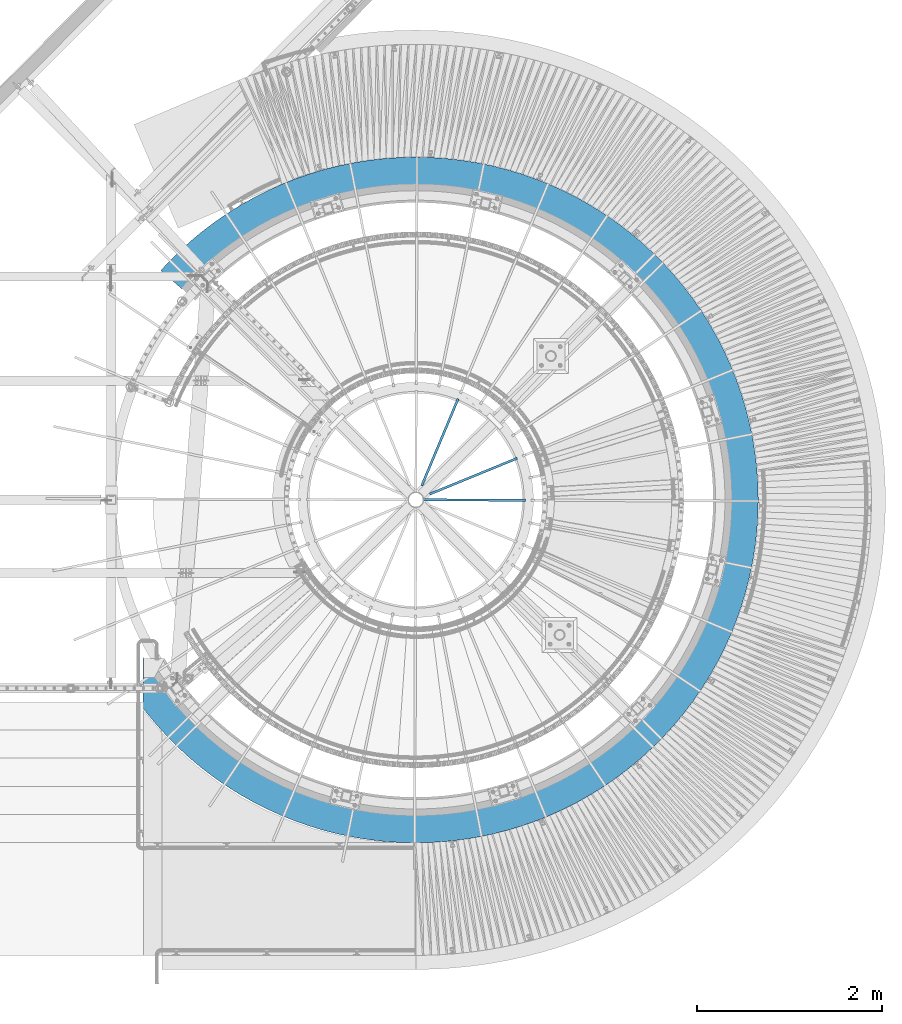
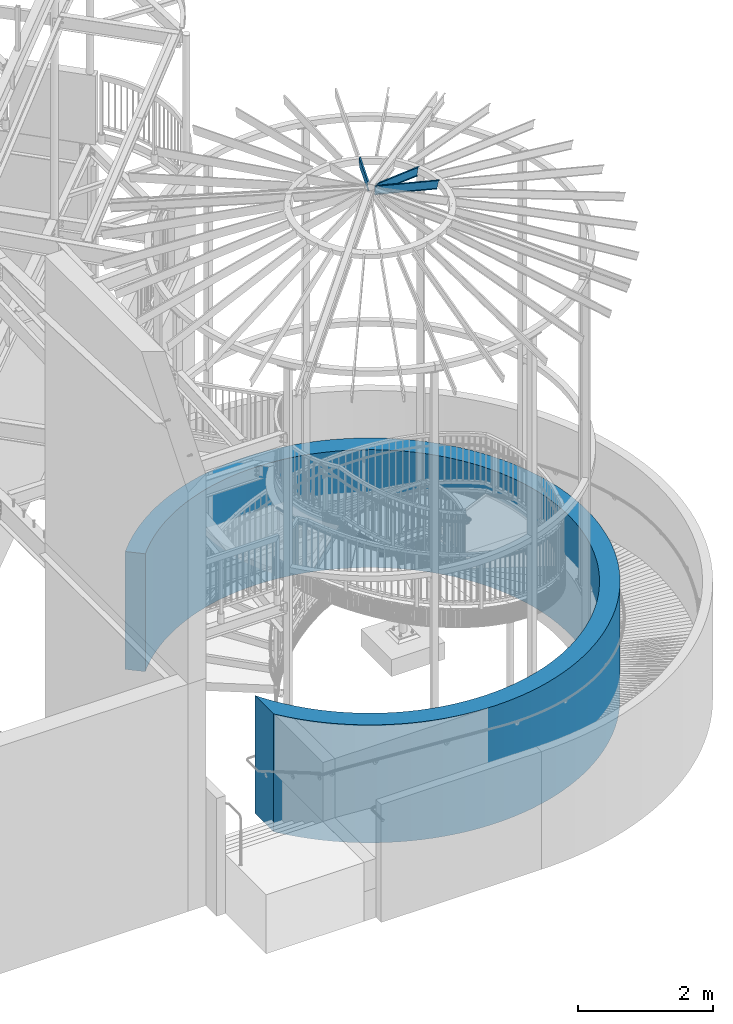
# One storey, part 350 of 975: 4 beams.
"""IFC2X3 building model written with IfcOpenShell, lengths in millimetres."""

from ifc_helpers import new_model, si_unit, frame, origin_with_axes, place, context, subcontext, project, spatial, faceted_brep, material, type_object, element, save


model = new_model("IFC2X3")

# Units and contexts
model_context = context("Model", 3, precision=1e-05, world=origin_with_axes())
body_context = subcontext(model_context, "Body", "Model", "MODEL_VIEW")
ifc_project = project(units=[si_unit("LENGTHUNIT", "METRE", prefix="MILLI"), si_unit("AREAUNIT", "SQUARE_METRE"), si_unit("VOLUMEUNIT", "CUBIC_METRE"), si_unit("MASSUNIT", "GRAM", prefix="KILO"), si_unit("TIMEUNIT", "SECOND"), si_unit("PLANEANGLEUNIT", "RADIAN"), si_unit("SOLIDANGLEUNIT", "STERADIAN"), si_unit("THERMODYNAMICTEMPERATUREUNIT", "DEGREE_CELSIUS"), si_unit("LUMINOUSINTENSITYUNIT", "LUMEN")], contexts=[model_context])

# Site, building, storey
site_placement = place(None, origin_with_axes())
site = spatial("IfcSite", under=ifc_project, at=site_placement, CompositionType="ELEMENT")
building_placement = place(site_placement, origin_with_axes())
building = spatial("IfcBuilding", under=site, at=building_placement, Name="Undefined", CompositionType="ELEMENT")
storey_placement = place(building_placement, origin_with_axes())
storey = spatial("IfcBuildingStorey", under=building, at=storey_placement, Name="Undefined", CompositionType="ELEMENT", Elevation=0.0)

# Beams
ifc_material = material(Name="STEEL/Zero_Density")
beam_type_1 = type_object("IfcBeamType", PredefinedType="NOTDEFINED")
beam_1_placement = place(storey_placement, frame((34730.3713409312, 3401.89164501969, 2133.6), z_axis=(0.0, -1.0, 0.0), x_axis=(0.0, 0.0, -1.0)))
element("IfcBeam", 1, at=beam_1_placement, inside=storey, type_object=beam_type_1, material=ifc_material, Name="WALL", context=body_context, shape_type="Brep", body=[
    faceted_brep([(2133.6, -2946.39999055969, 2250.34763282551), (0.0, -2946.39999055698, 2250.34763282907), (0.0, -2946.39996710213, 1702.37863439887), (2133.6, -2946.39996710377, 1702.37863439599), (2133.6, -2524.9126198538, -2281.19803068392), (0.0, -2524.91261985427, -2281.19803068341), (0.0, -2753.92744116245, -2482.30814659826), (2133.6, -2753.92744116215, -2482.3081465986), (0.0, -2921.81631390331, 1745.70398057874), (2133.6, -2921.81631390331, 1745.70398057874), (0.0, -2840.55352636582, 1875.03296607038), (2133.6, -2840.55352636582, 1875.03296607038), (0.0, -2753.57024205457, 2000.58588470266), (2133.6, -2753.57024205457, 2000.58588470266), (0.0, -2661.04163372819, 2122.10988960639), (2133.6, -2661.04163372819, 2122.10988960639), (0.0, -2563.15404168989, 2239.36024760841), (2133.6, -2563.15404168989, 2239.36024760841), (0.0, -2460.10459852291, 2352.10083209169), (2133.6, -2460.10459852291, 2352.10083209169), (0.0, -2352.10083209169, 2460.10459852291), (2133.6, -2352.10083209169, 2460.10459852291), (0.0, -2239.36024760841, 2563.15404168989), (2133.6, -2239.36024760841, 2563.15404168989), (0.0, -2122.10988960638, 2661.04163372819), (2133.6, -2122.10988960638, 2661.04163372819), (0.0, -2000.58588470266, 2753.57024205457), (2133.6, -2000.58588470266, 2753.57024205457), (0.0, -1875.03296607037, 2840.55352636583), (2133.6, -1875.03296607037, 2840.55352636583), (0.0, -1745.70398057874, 2921.81631390331), (2133.6, -1745.70398057874, 2921.81631390331), (0.0, -1612.8593795931, 2997.19495222759), (2133.6, -1612.8593795931, 2997.19495222759), (0.0, -1476.76669446052, 3066.53763879267), (2133.6, -1476.76669446052, 3066.53763879267), (0.0, -1337.69999773729, 3129.70472665612), (2133.6, -1337.69999773729, 3129.70472665612), (0.0, -1195.93935124326, 3186.56900570941), (2133.6, -1195.93935124326, 3186.56900570941), (0.0, -1051.77024205457, 3237.01595886219), (2133.6, -1051.77024205457, 3237.01595886219), (0.0, -905.483007570736, 3280.94399266441), (2133.6, -905.483007570736, 3280.94399266441), (0.0, -757.372250813714, 3318.26464190205), (2133.6, -757.372250813714, 3318.26464190205), (0.0, -607.736247136636, 3348.9027477543), (2133.6, -607.736247136636, 3348.9027477543), (0.0, -456.876343536969, 3372.79660915334), (2133.6, -456.876343536969, 3372.79660915334), (0.0, -305.096351783723, 3389.8981070422), (2133.6, -305.096351783723, 3389.8981070422), (0.0, -152.701936581012, 3400.17280128002), (2133.6, -152.701936581012, 3400.17280128002), (0.0, 0.0, 3403.6), (2133.6, 0.0, 3403.6), (0.0, 152.701936581012, 3400.17280128002), (2133.6, 152.701936581012, 3400.17280128002), (0.0, 305.09635178373, 3389.8981070422), (2133.6, 305.09635178373, 3389.8981070422), (0.0, 456.876343536969, 3372.79660915334), (2133.6, 456.876343536969, 3372.79660915334), (0.0, 607.736247136643, 3348.9027477543), (2133.6, 607.736247136643, 3348.9027477543), (0.0, 757.372250813714, 3318.26464190205), (2133.6, 757.372250813714, 3318.26464190205), (0.0, 905.483007570736, 3280.94399266441), (2133.6, 905.483007570736, 3280.94399266441), (0.0, 1051.77024205457, 3237.01595886218), (2133.6, 1051.77024205457, 3237.01595886218), (0.0, 1195.93935124326, 3186.56900570941), (2133.6, 1195.93935124326, 3186.56900570941), (0.0, 1337.6999977373, 3129.70472665612), (2133.6, 1337.6999977373, 3129.70472665612), (0.0, 1476.76669446052, 3066.53763879267), (2133.6, 1476.76669446052, 3066.53763879267), (0.0, 1612.8593795931, 2997.19495222759), (2133.6, 1612.8593795931, 2997.19495222759), (0.0, 1745.70398057874, 2921.81631390331), (2133.6, 1745.70398057874, 2921.81631390331), (0.0, 1875.03296607038, 2840.55352636583), (2133.6, 1875.03296607038, 2840.55352636583), (0.0, 2000.58588470266, 2753.57024205457), (2133.6, 2000.58588470266, 2753.57024205457), (0.0, 2122.10988960638, 2661.04163372819), (2133.6, 2122.10988960638, 2661.04163372819), (0.0, 2239.36024760841, 2563.15404168989), (2133.6, 2239.36024760841, 2563.15404168989), (0.0, 2352.1008320917, 2460.10459852291), (2133.6, 2352.1008320917, 2460.10459852291), (0.0, 2460.10459852291, 2352.10083209169), (2133.6, 2460.10459852291, 2352.10083209169), (0.0, 2563.15404168989, 2239.36024760841), (2133.6, 2563.15404168989, 2239.36024760841), (0.0, 2661.04163372819, 2122.10988960638), (2133.6, 2661.04163372819, 2122.10988960638), (0.0, 2753.57024205457, 2000.58588470266), (2133.6, 2753.57024205457, 2000.58588470266), (0.0, 2840.55352636582, 1875.03296607038), (2133.6, 2840.55352636582, 1875.03296607038), (0.0, 2921.81631390331, 1745.70398057874), (2133.6, 2921.81631390331, 1745.70398057874), (0.0, 2997.1949522276, 1612.8593795931), (2133.6, 2997.1949522276, 1612.8593795931), (0.0, 3066.53763879267, 1476.76669446052), (2133.6, 3066.53763879267, 1476.76669446052), (0.0, 3129.70472665612, 1337.69999773729), (2133.6, 3129.70472665612, 1337.69999773729), (0.0, 3186.56900570941, 1195.93935124326), (2133.6, 3186.56900570941, 1195.93935124326), (0.0, 3237.01595886218, 1051.77024205457), (2133.6, 3237.01595886218, 1051.77024205457), (0.0, 3280.9439926644, 905.483007570735), (2133.6, 3280.9439926644, 905.483007570735), (0.0, 3318.26464190205, 757.372250813711), (2133.6, 3318.26464190205, 757.372250813711), (0.0, 3348.9027477543, 607.736247136639), (2133.6, 3348.9027477543, 607.736247136639), (0.0, 3372.79660915335, 456.876343536971), (2133.6, 3372.79660915335, 456.876343536971), (0.0, 3389.89810704219, 305.096351783726), (2133.6, 3389.89810704219, 305.096351783726), (0.0, 3400.17280128002, 152.701936581012), (2133.6, 3400.17280128002, 152.701936581012), (0.0, 3403.6, -4.54747350886464e-13), (2133.6, 3403.6, -4.54747350886464e-13), (0.0, 3400.17280128002, -152.701936581013), (2133.6, 3400.17280128002, -152.701936581013), (0.0, 3389.89810704219, -305.096351783727), (2133.6, 3389.89810704219, -305.096351783727), (0.0, 3372.79660915335, -456.876343536972), (2133.6, 3372.79660915335, -456.876343536972), (0.0, 3348.9027477543, -607.73624713664), (2133.6, 3348.9027477543, -607.73624713664), (0.0, 3318.26464190205, -757.372250813712), (2133.6, 3318.26464190205, -757.372250813712), (0.0, 3280.9439926644, -905.483007570735), (2133.6, 3280.9439926644, -905.483007570735), (0.0, 3237.01595886218, -1051.77024205457), (2133.6, 3237.01595886218, -1051.77024205457), (0.0, 3186.56900570941, -1195.93935124326), (2133.6, 3186.56900570941, -1195.93935124326), (0.0, 3129.70472665612, -1337.69999773729), (2133.6, 3129.70472665612, -1337.69999773729), (0.0, 3066.53763879267, -1476.76669446052), (2133.6, 3066.53763879267, -1476.76669446052), (0.0, 2997.1949522276, -1612.8593795931), (2133.6, 2997.1949522276, -1612.8593795931), (0.0, 2921.81631390331, -1745.70398057874), (2133.6, 2921.81631390331, -1745.70398057874), (0.0, 2840.55352636582, -1875.03296607038), (2133.6, 2840.55352636582, -1875.03296607038), (0.0, 2753.57024205457, -2000.58588470266), (2133.6, 2753.57024205457, -2000.58588470266), (0.0, 2661.04163372819, -2122.10988960639), (2133.6, 2661.04163372819, -2122.10988960639), (0.0, 2563.15404168989, -2239.36024760841), (2133.6, 2563.15404168989, -2239.36024760841), (0.0, 2460.10459852291, -2352.10083209169), (2133.6, 2460.10459852291, -2352.10083209169), (0.0, 2352.1008320917, -2460.10459852291), (2133.6, 2352.1008320917, -2460.10459852291), (0.0, 2239.36024760841, -2563.15404168989), (2133.6, 2239.36024760841, -2563.15404168989), (0.0, 2122.10988960638, -2661.04163372819), (2133.6, 2122.10988960638, -2661.04163372819), (0.0, 2000.58588470266, -2753.57024205457), (2133.6, 2000.58588470266, -2753.57024205457), (0.0, 1875.03296607038, -2840.55352636583), (2133.6, 1875.03296607038, -2840.55352636583), (0.0, 1745.70398057874, -2921.81631390331), (2133.6, 1745.70398057874, -2921.81631390331), (0.0, 1612.8593795931, -2997.19495222759), (2133.6, 1612.8593795931, -2997.19495222759), (0.0, 1476.76669446052, -3066.53763879267), (2133.6, 1476.76669446052, -3066.53763879267), (0.0, 1337.69999773729, -3129.70472665612), (2133.6, 1337.69999773729, -3129.70472665612), (0.0, 1195.93935124326, -3186.56900570941), (2133.6, 1195.93935124326, -3186.56900570941), (0.0, 1051.77024205457, -3237.01595886219), (2133.6, 1051.77024205457, -3237.01595886219), (0.0, 905.483007570736, -3280.94399266441), (2133.6, 905.483007570736, -3280.94399266441), (0.0, 757.372250813714, -3318.26464190205), (2133.6, 757.372250813714, -3318.26464190205), (0.0, 607.736247136636, -3348.9027477543), (2133.6, 607.736247136636, -3348.9027477543), (0.0, 456.876343536969, -3372.79660915334), (2133.6, 456.876343536969, -3372.79660915334), (0.0, 305.096351783723, -3389.8981070422), (2133.6, 305.096351783723, -3389.8981070422), (0.0, 152.701936581012, -3400.17280128002), (2133.6, 152.701936581012, -3400.17280128002), (0.0, 0.0, -3403.6), (2133.6, 0.0, -3403.6), (0.0, -152.701936581012, -3400.17280128002), (2133.6, -152.701936581012, -3400.17280128002), (0.0, -305.09635178373, -3389.8981070422), (2133.6, -305.09635178373, -3389.8981070422), (0.0, -456.876343536969, -3372.79660915334), (2133.6, -456.876343536969, -3372.79660915334), (0.0, -607.736247136643, -3348.9027477543), (2133.6, -607.736247136643, -3348.9027477543), (0.0, -757.372250813714, -3318.26464190205), (2133.6, -757.372250813714, -3318.26464190205), (0.0, -905.483007570736, -3280.94399266441), (2133.6, -905.483007570736, -3280.94399266441), (0.0, -1051.77024205457, -3237.01595886218), (2133.6, -1051.77024205457, -3237.01595886218), (0.0, -1195.93935124326, -3186.56900570941), (2133.6, -1195.93935124326, -3186.56900570941), (0.0, -1337.6999977373, -3129.70472665612), (2133.6, -1337.6999977373, -3129.70472665612), (0.0, -1476.76669446052, -3066.53763879267), (2133.6, -1476.76669446052, -3066.53763879267), (0.0, -1612.8593795931, -2997.19495222759), (2133.6, -1612.8593795931, -2997.19495222759), (0.0, -1745.70398057874, -2921.81631390331), (2133.6, -1745.70398057874, -2921.81631390331), (0.0, -1875.03296607038, -2840.55352636583), (2133.6, -1875.03296607038, -2840.55352636583), (0.0, -2000.58588470266, -2753.57024205457), (2133.6, -2000.58588470266, -2753.57024205457), (0.0, -2122.10988960638, -2661.04163372819), (2133.6, -2122.10988960638, -2661.04163372819), (0.0, -2239.36024760841, -2563.15404168989), (2133.6, -2239.36024760841, -2563.15404168989), (0.0, -2352.10083209169, -2460.10459852291), (2133.6, -2352.10083209169, -2460.10459852291), (0.0, -2460.10459852291, -2352.10083209169), (2133.6, -2460.10459852291, -2352.10083209169), (0.0, -2680.4124730175, -2562.73672750289), (2133.6, -2680.4124730175, -2562.73672750289), (0.0, -2562.73672750289, -2680.4124730175), (2133.6, -2562.73672750289, -2680.4124730175), (0.0, -2439.89997127483, -2792.69022452779), (2133.6, -2439.89997127483, -2792.69022452779), (0.0, -2312.14958121293, -2899.34386958444), (2133.6, -2312.14958121293, -2899.34386958444), (0.0, -2179.74282960141, -3000.15862194006), (2133.6, -2179.74282960141, -3000.15862194006), (0.0, -2042.94636601697, -3094.93145410008), (2133.6, -2042.94636601697, -3094.93145410008), (0.0, -1902.03568033206, -3183.47150619316), (2133.6, -1902.03568033206, -3183.47150619316), (0.0, -1757.29454791487, -3265.60047033753), (2133.6, -1757.29454791487, -3265.60047033753), (0.0, -1609.01445814355, -3341.15294972933), (2133.6, -1609.01445814355, -3341.15294972933), (0.0, -1457.49402738541, -3409.9767917298), (2133.6, -1457.49402738541, -3409.9767917298), (0.0, -1303.03839762325, -3471.9333942804), (2133.6, -1303.03839762325, -3471.9333942804), (0.0, -1145.95862194005, -3526.89798502895), (2133.6, -1145.95862194005, -3526.89798502895), (0.0, -986.571038099457, -3574.7598726045), (2133.6, -986.571038099457, -3574.7598726045), (0.0, -825.196631483595, -3615.42266953507), (2133.6, -825.196631483595, -3615.42266953507), (0.0, -662.160388671262, -3648.80448635916), (2133.6, -662.160388671262, -3648.80448635916), (0.0, -497.790642958193, -3674.83809654021), (2133.6, -497.790642958193, -3674.83809654021), (0.0, -332.418413137493, -3693.47107185194), (2133.6, -332.418413137493, -3693.47107185194), (0.0, -166.376736871847, -3704.66588796181), (2133.6, -166.376736871847, -3704.66588796181), (0.0, 0.0, -3708.4), (2133.6, 0.0, -3708.4), (0.0, 166.376736871847, -3704.66588796181), (2133.6, 166.376736871847, -3704.66588796181), (0.0, 332.418413137493, -3693.47107185194), (2133.6, 332.418413137493, -3693.47107185194), (0.0, 497.790642958193, -3674.83809654021), (2133.6, 497.790642958193, -3674.83809654021), (0.0, 662.160388671262, -3648.80448635916), (2133.6, 662.160388671262, -3648.80448635916), (0.0, 825.196631483595, -3615.42266953507), (2133.6, 825.196631483595, -3615.42266953507), (0.0, 986.571038099457, -3574.7598726045), (2133.6, 986.571038099457, -3574.7598726045), (0.0, 1145.95862194006, -3526.89798502895), (2133.6, 1145.95862194006, -3526.89798502895), (0.0, 1303.03839762326, -3471.9333942804), (2133.6, 1303.03839762326, -3471.9333942804), (0.0, 1457.49402738541, -3409.9767917298), (2133.6, 1457.49402738541, -3409.9767917298), (0.0, 1609.01445814355, -3341.15294972933), (2133.6, 1609.01445814355, -3341.15294972933), (0.0, 1757.29454791487, -3265.60047033753), (2133.6, 1757.29454791487, -3265.60047033753), (0.0, 1902.03568033206, -3183.47150619316), (2133.6, 1902.03568033206, -3183.47150619316), (0.0, 2042.94636601698, -3094.93145410008), (2133.6, 2042.94636601698, -3094.93145410008), (0.0, 2179.74282960141, -3000.15862194005), (2133.6, 2179.74282960141, -3000.15862194005), (0.0, 2312.14958121293, -2899.34386958444), (2133.6, 2312.14958121293, -2899.34386958444), (0.0, 2439.89997127483, -2792.69022452779), (2133.6, 2439.89997127483, -2792.69022452779), (0.0, 2562.73672750289, -2680.4124730175), (2133.6, 2562.73672750289, -2680.4124730175), (0.0, 2680.4124730175, -2562.73672750289), (2133.6, 2680.4124730175, -2562.73672750289), (0.0, 2792.69022452779, -2439.89997127483), (2133.6, 2792.69022452779, -2439.89997127483), (0.0, 2899.34386958445, -2312.14958121293), (2133.6, 2899.34386958445, -2312.14958121293), (0.0, 3000.15862194006, -2179.74282960141), (2133.6, 3000.15862194006, -2179.74282960141), (0.0, 3094.93145410008, -2042.94636601698), (2133.6, 3094.93145410008, -2042.94636601698), (0.0, 3183.47150619316, -1902.03568033206), (2133.6, 3183.47150619316, -1902.03568033206), (0.0, 3265.60047033753, -1757.29454791487), (2133.6, 3265.60047033753, -1757.29454791487), (0.0, 3341.15294972933, -1609.01445814355), (2133.6, 3341.15294972933, -1609.01445814355), (0.0, 3409.9767917298, -1457.49402738541), (2133.6, 3409.9767917298, -1457.49402738541), (0.0, 3471.9333942804, -1303.03839762325), (2133.6, 3471.9333942804, -1303.03839762325), (0.0, 3526.89798502895, -1145.95862194005), (2133.6, 3526.89798502895, -1145.95862194005), (0.0, 3574.7598726045, -986.571038099457), (2133.6, 3574.7598726045, -986.571038099457), (0.0, 3615.42266953507, -825.196631483596), (2133.6, 3615.42266953507, -825.196631483596), (0.0, 3648.80448635916, -662.160388671264), (2133.6, 3648.80448635916, -662.160388671264), (0.0, 3674.83809654021, -497.790642958193), (2133.6, 3674.83809654021, -497.790642958193), (0.0, 3693.47107185194, -332.418413137492), (2133.6, 3693.47107185194, -332.418413137492), (0.0, 3704.66588796181, -166.376736871849), (2133.6, 3704.66588796181, -166.376736871849), (0.0, 3708.4, 4.54747350886464e-13), (2133.6, 3708.4, 4.54747350886464e-13), (0.0, 3704.66588796181, 166.37673687185), (2133.6, 3704.66588796181, 166.37673687185), (0.0, 3693.47107185194, 332.418413137493), (2133.6, 3693.47107185194, 332.418413137493), (0.0, 3674.83809654021, 497.790642958194), (2133.6, 3674.83809654021, 497.790642958194), (0.0, 3648.80448635916, 662.160388671265), (2133.6, 3648.80448635916, 662.160388671265), (0.0, 3615.42266953507, 825.196631483597), (2133.6, 3615.42266953507, 825.196631483597), (0.0, 3574.7598726045, 986.571038099458), (2133.6, 3574.7598726045, 986.571038099458), (0.0, 3526.89798502895, 1145.95862194006), (2133.6, 3526.89798502895, 1145.95862194006), (0.0, 3471.9333942804, 1303.03839762325), (2133.6, 3471.9333942804, 1303.03839762325), (0.0, 3409.9767917298, 1457.49402738541), (2133.6, 3409.9767917298, 1457.49402738541), (0.0, 3341.15294972933, 1609.01445814355), (2133.6, 3341.15294972933, 1609.01445814355), (0.0, 3265.60047033753, 1757.29454791487), (2133.6, 3265.60047033753, 1757.29454791487), (0.0, 3183.47150619316, 1902.03568033206), (2133.6, 3183.47150619316, 1902.03568033206), (0.0, 3094.93145410008, 2042.94636601698), (2133.6, 3094.93145410008, 2042.94636601698), (0.0, 3000.15862194006, 2179.74282960141), (2133.6, 3000.15862194006, 2179.74282960141), (0.0, 2899.34386958444, 2312.14958121293), (2133.6, 2899.34386958444, 2312.14958121293), (0.0, 2792.69022452779, 2439.89997127483), (2133.6, 2792.69022452779, 2439.89997127483), (0.0, 2680.4124730175, 2562.73672750289), (2133.6, 2680.4124730175, 2562.73672750289), (0.0, 2562.73672750289, 2680.4124730175), (2133.6, 2562.73672750289, 2680.4124730175), (0.0, 2439.89997127483, 2792.69022452779), (2133.6, 2439.89997127483, 2792.69022452779), (0.0, 2312.14958121293, 2899.34386958444), (2133.6, 2312.14958121293, 2899.34386958444), (0.0, 2179.7428296014, 3000.15862194006), (2133.6, 2179.7428296014, 3000.15862194006), (0.0, 2042.94636601698, 3094.93145410008), (2133.6, 2042.94636601698, 3094.93145410008), (0.0, 1902.03568033206, 3183.47150619316), (2133.6, 1902.03568033206, 3183.47150619316), (0.0, 1757.29454791487, 3265.60047033753), (2133.6, 1757.29454791487, 3265.60047033753), (0.0, 1609.01445814355, 3341.15294972933), (2133.6, 1609.01445814355, 3341.15294972933), (0.0, 1457.49402738541, 3409.9767917298), (2133.6, 1457.49402738541, 3409.9767917298), (0.0, 1303.03839762325, 3471.9333942804), (2133.6, 1303.03839762325, 3471.9333942804), (0.0, 1145.95862194005, 3526.89798502895), (2133.6, 1145.95862194005, 3526.89798502895), (0.0, 986.571038099457, 3574.7598726045), (2133.6, 986.571038099457, 3574.7598726045), (0.0, 825.196631483595, 3615.42266953507), (2133.6, 825.196631483595, 3615.42266953507), (0.0, 662.160388671262, 3648.80448635916), (2133.6, 662.160388671262, 3648.80448635916), (0.0, 497.790642958193, 3674.83809654021), (2133.6, 497.790642958193, 3674.83809654021), (0.0, 332.418413137493, 3693.47107185194), (2133.6, 332.418413137493, 3693.47107185194), (0.0, 166.376736871847, 3704.66588796181), (2133.6, 166.376736871847, 3704.66588796181), (0.0, 0.0, 3708.4), (2133.6, 0.0, 3708.4), (0.0, -166.376736871847, 3704.66588796181), (2133.6, -166.376736871847, 3704.66588796181), (0.0, -332.418413137493, 3693.47107185194), (2133.6, -332.418413137493, 3693.47107185194), (0.0, -497.790642958193, 3674.83809654021), (2133.6, -497.790642958193, 3674.83809654021), (0.0, -662.160388671262, 3648.80448635916), (2133.6, -662.160388671262, 3648.80448635916), (0.0, -825.196631483595, 3615.42266953507), (2133.6, -825.196631483595, 3615.42266953507), (0.0, -986.571038099457, 3574.7598726045), (2133.6, -986.571038099457, 3574.7598726045), (0.0, -1145.95862194005, 3526.89798502895), (2133.6, -1145.95862194005, 3526.89798502895), (0.0, -1303.03839762326, 3471.9333942804), (2133.6, -1303.03839762326, 3471.9333942804), (0.0, -1457.49402738541, 3409.9767917298), (2133.6, -1457.49402738541, 3409.9767917298), (0.0, -1609.01445814355, 3341.15294972933), (2133.6, -1609.01445814355, 3341.15294972933), (0.0, -1757.29454791487, 3265.60047033753), (2133.6, -1757.29454791487, 3265.60047033753), (0.0, -1902.03568033206, 3183.47150619316), (2133.6, -1902.03568033206, 3183.47150619316), (0.0, -2042.94636601698, 3094.93145410008), (2133.6, -2042.94636601698, 3094.93145410008), (0.0, -2179.74282960141, 3000.15862194006), (2133.6, -2179.74282960141, 3000.15862194006), (0.0, -2312.14958121293, 2899.34386958444), (2133.6, -2312.14958121293, 2899.34386958444), (0.0, -2439.89997127483, 2792.69022452779), (2133.6, -2439.89997127483, 2792.69022452779), (0.0, -2562.73672750289, 2680.4124730175), (2133.6, -2562.73672750289, 2680.4124730175), (0.0, -2680.4124730175, 2562.73672750289), (2133.6, -2680.4124730175, 2562.73672750289), (0.0, -2792.69022452779, 2439.89997127483), (2133.6, -2792.69022452779, 2439.89997127483), (2133.6, -2899.34386958444, 2312.14958121293), (0.0, -2899.34386958444, 2312.14958121293)], [[[0, 1, 2, 3]], [[4, 5, 6, 7]], [[8, 9, 3, 2]], [[8, 10, 11, 9]], [[10, 12, 13, 11]], [[12, 14, 15, 13]], [[14, 16, 17, 15]], [[16, 18, 19, 17]], [[18, 20, 21, 19]], [[20, 22, 23, 21]], [[22, 24, 25, 23]], [[24, 26, 27, 25]], [[26, 28, 29, 27]], [[28, 30, 31, 29]], [[30, 32, 33, 31]], [[32, 34, 35, 33]], [[34, 36, 37, 35]], [[36, 38, 39, 37]], [[38, 40, 41, 39]], [[40, 42, 43, 41]], [[42, 44, 45, 43]], [[44, 46, 47, 45]], [[46, 48, 49, 47]], [[48, 50, 51, 49]], [[50, 52, 53, 51]], [[52, 54, 55, 53]], [[54, 56, 57, 55]], [[56, 58, 59, 57]], [[58, 60, 61, 59]], [[60, 62, 63, 61]], [[62, 64, 65, 63]], [[64, 66, 67, 65]], [[66, 68, 69, 67]], [[68, 70, 71, 69]], [[70, 72, 73, 71]], [[72, 74, 75, 73]], [[74, 76, 77, 75]], [[76, 78, 79, 77]], [[78, 80, 81, 79]], [[80, 82, 83, 81]], [[82, 84, 85, 83]], [[84, 86, 87, 85]], [[86, 88, 89, 87]], [[88, 90, 91, 89]], [[90, 92, 93, 91]], [[92, 94, 95, 93]], [[94, 96, 97, 95]], [[96, 98, 99, 97]], [[98, 100, 101, 99]], [[100, 102, 103, 101]], [[102, 104, 105, 103]], [[104, 106, 107, 105]], [[106, 108, 109, 107]], [[108, 110, 111, 109]], [[110, 112, 113, 111]], [[112, 114, 115, 113]], [[114, 116, 117, 115]], [[116, 118, 119, 117]], [[118, 120, 121, 119]], [[120, 122, 123, 121]], [[122, 124, 125, 123]], [[124, 126, 127, 125]], [[126, 128, 129, 127]], [[128, 130, 131, 129]], [[130, 132, 133, 131]], [[132, 134, 135, 133]], [[134, 136, 137, 135]], [[136, 138, 139, 137]], [[138, 140, 141, 139]], [[140, 142, 143, 141]], [[142, 144, 145, 143]], [[144, 146, 147, 145]], [[146, 148, 149, 147]], [[148, 150, 151, 149]], [[150, 152, 153, 151]], [[152, 154, 155, 153]], [[154, 156, 157, 155]], [[156, 158, 159, 157]], [[158, 160, 161, 159]], [[160, 162, 163, 161]], [[162, 164, 165, 163]], [[164, 166, 167, 165]], [[166, 168, 169, 167]], [[168, 170, 171, 169]], [[170, 172, 173, 171]], [[172, 174, 175, 173]], [[174, 176, 177, 175]], [[176, 178, 179, 177]], [[178, 180, 181, 179]], [[180, 182, 183, 181]], [[182, 184, 185, 183]], [[184, 186, 187, 185]], [[186, 188, 189, 187]], [[188, 190, 191, 189]], [[190, 192, 193, 191]], [[192, 194, 195, 193]], [[194, 196, 197, 195]], [[196, 198, 199, 197]], [[198, 200, 201, 199]], [[200, 202, 203, 201]], [[202, 204, 205, 203]], [[204, 206, 207, 205]], [[206, 208, 209, 207]], [[208, 210, 211, 209]], [[210, 212, 213, 211]], [[212, 214, 215, 213]], [[214, 216, 217, 215]], [[216, 218, 219, 217]], [[218, 220, 221, 219]], [[220, 222, 223, 221]], [[222, 224, 225, 223]], [[224, 226, 227, 225]], [[226, 228, 229, 227]], [[228, 230, 231, 229]], [[232, 233, 7, 6]], [[232, 234, 235, 233]], [[234, 236, 237, 235]], [[236, 238, 239, 237]], [[238, 240, 241, 239]], [[240, 242, 243, 241]], [[242, 244, 245, 243]], [[244, 246, 247, 245]], [[246, 248, 249, 247]], [[248, 250, 251, 249]], [[250, 252, 253, 251]], [[252, 254, 255, 253]], [[254, 256, 257, 255]], [[256, 258, 259, 257]], [[258, 260, 261, 259]], [[260, 262, 263, 261]], [[262, 264, 265, 263]], [[264, 266, 267, 265]], [[266, 268, 269, 267]], [[268, 270, 271, 269]], [[270, 272, 273, 271]], [[272, 274, 275, 273]], [[274, 276, 277, 275]], [[276, 278, 279, 277]], [[278, 280, 281, 279]], [[280, 282, 283, 281]], [[282, 284, 285, 283]], [[284, 286, 287, 285]], [[286, 288, 289, 287]], [[288, 290, 291, 289]], [[290, 292, 293, 291]], [[292, 294, 295, 293]], [[294, 296, 297, 295]], [[296, 298, 299, 297]], [[298, 300, 301, 299]], [[300, 302, 303, 301]], [[302, 304, 305, 303]], [[304, 306, 307, 305]], [[306, 308, 309, 307]], [[308, 310, 311, 309]], [[310, 312, 313, 311]], [[312, 314, 315, 313]], [[314, 316, 317, 315]], [[316, 318, 319, 317]], [[318, 320, 321, 319]], [[320, 322, 323, 321]], [[322, 324, 325, 323]], [[324, 326, 327, 325]], [[326, 328, 329, 327]], [[328, 330, 331, 329]], [[330, 332, 333, 331]], [[332, 334, 335, 333]], [[334, 336, 337, 335]], [[336, 338, 339, 337]], [[338, 340, 341, 339]], [[340, 342, 343, 341]], [[342, 344, 345, 343]], [[344, 346, 347, 345]], [[346, 348, 349, 347]], [[348, 350, 351, 349]], [[350, 352, 353, 351]], [[352, 354, 355, 353]], [[354, 356, 357, 355]], [[356, 358, 359, 357]], [[358, 360, 361, 359]], [[360, 362, 363, 361]], [[362, 364, 365, 363]], [[364, 366, 367, 365]], [[366, 368, 369, 367]], [[368, 370, 371, 369]], [[370, 372, 373, 371]], [[372, 374, 375, 373]], [[374, 376, 377, 375]], [[376, 378, 379, 377]], [[378, 380, 381, 379]], [[380, 382, 383, 381]], [[382, 384, 385, 383]], [[384, 386, 387, 385]], [[386, 388, 389, 387]], [[388, 390, 391, 389]], [[390, 392, 393, 391]], [[392, 394, 395, 393]], [[394, 396, 397, 395]], [[396, 398, 399, 397]], [[398, 400, 401, 399]], [[400, 402, 403, 401]], [[402, 404, 405, 403]], [[404, 406, 407, 405]], [[406, 408, 409, 407]], [[408, 410, 411, 409]], [[410, 412, 413, 411]], [[412, 414, 415, 413]], [[414, 416, 417, 415]], [[416, 418, 419, 417]], [[418, 420, 421, 419]], [[420, 422, 423, 421]], [[422, 424, 425, 423]], [[424, 426, 427, 425]], [[426, 428, 429, 427]], [[428, 430, 431, 429]], [[430, 432, 433, 431]], [[432, 434, 435, 433]], [[434, 436, 437, 435]], [[436, 438, 439, 437]], [[438, 440, 441, 439]], [[440, 442, 443, 441]], [[442, 444, 445, 443]], [[444, 446, 447, 445]], [[9, 11, 13, 15, 17, 19, 21, 23, 25, 27, 29, 31, 33, 35, 37, 39, 41, 43, 45, 47, 49, 51, 53, 55, 57, 59, 61, 63, 65, 67, 69, 71, 73, 75, 77, 79, 81, 83, 85, 87, 89, 91, 93, 95, 97, 99, 101, 103, 105, 107, 109, 111, 113, 115, 117, 119, 121, 123, 125, 127, 129, 131, 133, 135, 137, 139, 141, 143, 145, 147, 149, 151, 153, 155, 157, 159, 161, 163, 165, 167, 169, 171, 173, 175, 177, 179, 181, 183, 185, 187, 189, 191, 193, 195, 197, 199, 201, 203, 205, 207, 209, 211, 213, 215, 217, 219, 221, 223, 225, 227, 229, 231, 4, 7, 233, 235, 237, 239, 241, 243, 245, 247, 249, 251, 253, 255, 257, 259, 261, 263, 265, 267, 269, 271, 273, 275, 277, 279, 281, 283, 285, 287, 289, 291, 293, 295, 297, 299, 301, 303, 305, 307, 309, 311, 313, 315, 317, 319, 321, 323, 325, 327, 329, 331, 333, 335, 337, 339, 341, 343, 345, 347, 349, 351, 353, 355, 357, 359, 361, 363, 365, 367, 369, 371, 373, 375, 377, 379, 381, 383, 385, 387, 389, 391, 393, 395, 397, 399, 401, 403, 405, 407, 409, 411, 413, 415, 417, 419, 421, 423, 425, 427, 429, 431, 433, 435, 437, 439, 441, 443, 445, 447, 448, 0, 3]], [[446, 449, 448, 447]], [[448, 449, 1, 0]], [[449, 446, 444, 442, 440, 438, 436, 434, 432, 430, 428, 426, 424, 422, 420, 418, 416, 414, 412, 410, 408, 406, 404, 402, 400, 398, 396, 394, 392, 390, 388, 386, 384, 382, 380, 378, 376, 374, 372, 370, 368, 366, 364, 362, 360, 358, 356, 354, 352, 350, 348, 346, 344, 342, 340, 338, 336, 334, 332, 330, 328, 326, 324, 322, 320, 318, 316, 314, 312, 310, 308, 306, 304, 302, 300, 298, 296, 294, 292, 290, 288, 286, 284, 282, 280, 278, 276, 274, 272, 270, 268, 266, 264, 262, 260, 258, 256, 254, 252, 250, 248, 246, 244, 242, 240, 238, 236, 234, 232, 6, 5, 230, 228, 226, 224, 222, 220, 218, 216, 214, 212, 210, 208, 206, 204, 202, 200, 198, 196, 194, 192, 190, 188, 186, 184, 182, 180, 178, 176, 174, 172, 170, 168, 166, 164, 162, 160, 158, 156, 154, 152, 150, 148, 146, 144, 142, 140, 138, 136, 134, 132, 130, 128, 126, 124, 122, 120, 118, 116, 114, 112, 110, 108, 106, 104, 102, 100, 98, 96, 94, 92, 90, 88, 86, 84, 82, 80, 78, 76, 74, 72, 70, 68, 66, 64, 62, 60, 58, 56, 54, 52, 50, 48, 46, 44, 42, 40, 38, 36, 34, 32, 30, 28, 26, 24, 22, 20, 18, 16, 14, 12, 10, 8, 2, 1]], [[231, 230, 5, 4]]]),
])
beam_type_2 = type_object("IfcBeamType", PredefinedType="NOTDEFINED")
beam_2_placement = place(storey_placement, frame((34795.0032874501, 3428.77658385418, 9185.06096723024), z_axis=(0.224418098973874, 0.0919951519892898, 0.970140922167197), x_axis=(0.897647574487811, 0.367970434790039, -0.242541936861608)))
element("IfcBeam", 2, at=beam_2_placement, inside=storey, type_object=beam_type_2, material=ifc_material, Name="STUD", context=body_context, shape_type="Brep", body=[
    faceted_brep([(1134.70057945789, -12.6999999990348, 76.200000000108), (1134.70057945789, -12.6999999990367, 73.0250000001097), (1134.70057945792, 9.52500000095824, 73.025000000097), (1134.70057945806, 9.52500000092914, -73.0249999998405), (1134.70057945804, -12.6999999990658, -73.0249999998296), (1134.70057945805, -12.6999999990658, -76.1999999998279), (1134.70057945806, 12.7000000009302, -76.1999999998443), (1134.70057945791, 12.700000000963, 76.2000000000953), (120.622594087679, -12.6999999999171, -76.1999999999462), (120.622594117929, 12.7000000000808, -76.1999999999607), (82.521540679696, 12.7000000000753, 76.1999999999753), (82.521540649439, -12.6999999999171, 76.1999999999898), (83.3153125960707, -12.6999999999189, 73.0249999999905), (83.3153126225407, 9.52500000007603, 73.0249999999796), (119.828822167521, 9.52500000007785, -73.0249999999578), (119.828822141044, -12.6999999999152, -73.0249999999469)], [[[0, 1, 2, 3, 4, 5, 6, 7]], [[6, 5, 8, 9]], [[7, 6, 9, 10]], [[0, 7, 10, 11]], [[1, 0, 11, 12]], [[2, 1, 12, 13]], [[3, 2, 13, 14]], [[4, 3, 14, 15]], [[5, 4, 15, 8]], [[14, 13, 12, 11, 10, 9, 8, 15]]]),
])
beam_3_placement = place(storey_placement, frame((34759.4797516697, 3464.18481801047, 9185.06096723024), z_axis=(0.0936371633068046, 0.223737955733079, 0.970140922140818), x_axis=(0.374538296949224, 0.894927076878677, -0.242541936967119)))
element("IfcBeam", 3, at=beam_3_placement, inside=storey, type_object=beam_type_2, material=ifc_material, Name="STUD", context=body_context, shape_type="Brep", body=[
    faceted_brep([(1134.70057945789, -12.6999999990348, 76.200000000108), (1134.70057945789, -12.6999999990367, 73.0250000001097), (1134.70057945792, 9.52500000095824, 73.025000000097), (1134.70057945806, 9.52500000092914, -73.0249999998405), (1134.70057945804, -12.6999999990658, -73.0249999998296), (1134.70057945805, -12.6999999990658, -76.1999999998279), (1134.70057945806, 12.7000000009302, -76.1999999998443), (1134.70057945791, 12.700000000963, 76.2000000000953), (124.283917888468, -12.7000000001171, -76.1999999999734), (124.283917926634, 12.6999999999316, -76.1999999999898), (86.1828643469635, 12.6999999999425, 76.200000000108), (86.1828643088047, -12.7000000001062, 76.2000000001244), (86.9766362583796, -12.7000000001099, 73.0250000001215), (86.9766362917726, 9.52499999993961, 73.0250000001079), (123.490145972286, 9.52499999993233, -73.0249999999851), (123.490145938893, -12.7000000001171, -73.0249999999724)], [[[0, 1, 2, 3, 4, 5, 6, 7]], [[6, 5, 8, 9]], [[7, 6, 9, 10]], [[0, 7, 10, 11]], [[1, 0, 11, 12]], [[2, 1, 12, 13]], [[3, 2, 13, 14]], [[4, 3, 14, 15]], [[5, 4, 15, 8]], [[14, 13, 12, 11, 10, 9, 8, 15]]]),
])
beam_4_placement = place(storey_placement, frame((34800.0324104494, 3403.70652481064, 9185.06096723024), z_axis=(0.242540308898344, -0.000888649999627433, 0.970140922165782), x_axis=(0.970134410469096, -0.00355450199805463, -0.242541936867269)))
element("IfcBeam", 4, at=beam_4_placement, inside=storey, type_object=beam_type_2, material=ifc_material, Name="STUD", context=body_context, shape_type="Brep", body=[
    faceted_brep([(1134.70057945789, -12.6999999990348, 76.200000000108), (1134.70057945789, -12.6999999990367, 73.0250000001097), (1134.70057945792, 9.52500000095824, 73.025000000097), (1134.70057945806, 9.52500000092914, -73.0249999998405), (1134.70057945804, -12.6999999990658, -73.0249999998296), (1134.70057945805, -12.6999999990658, -76.1999999998279), (1134.70057945806, 12.7000000009302, -76.1999999998443), (1134.70057945791, 12.700000000963, 76.2000000000953), (38.1010538948394, -12.7000000000157, -76.1999999999643), (38.1010539016352, 12.6999999999862, -76.1999999999662), (1.96450855582952e-10, 12.7000000001644, 76.2000000001021), (1.74622982740402e-10, -12.6999999998661, 76.2000000000985), (0.79377234254207, -12.699999999993, 73.0249999999905), (0.793772348486527, 9.52500000000873, 73.0249999999905), (37.3072819528606, 9.52499999998645, -73.0249999999669), (37.3072819469235, -12.7000000000148, -73.0249999999651)], [[[0, 1, 2, 3, 4, 5, 6, 7]], [[6, 5, 8, 9]], [[7, 6, 9, 10]], [[0, 7, 10, 11]], [[1, 0, 11, 12]], [[2, 1, 12, 13]], [[3, 2, 13, 14]], [[4, 3, 14, 15]], [[5, 4, 15, 8]], [[14, 13, 12, 11, 10, 9, 8, 15]]]),
])

save(model, "model.ifc")
